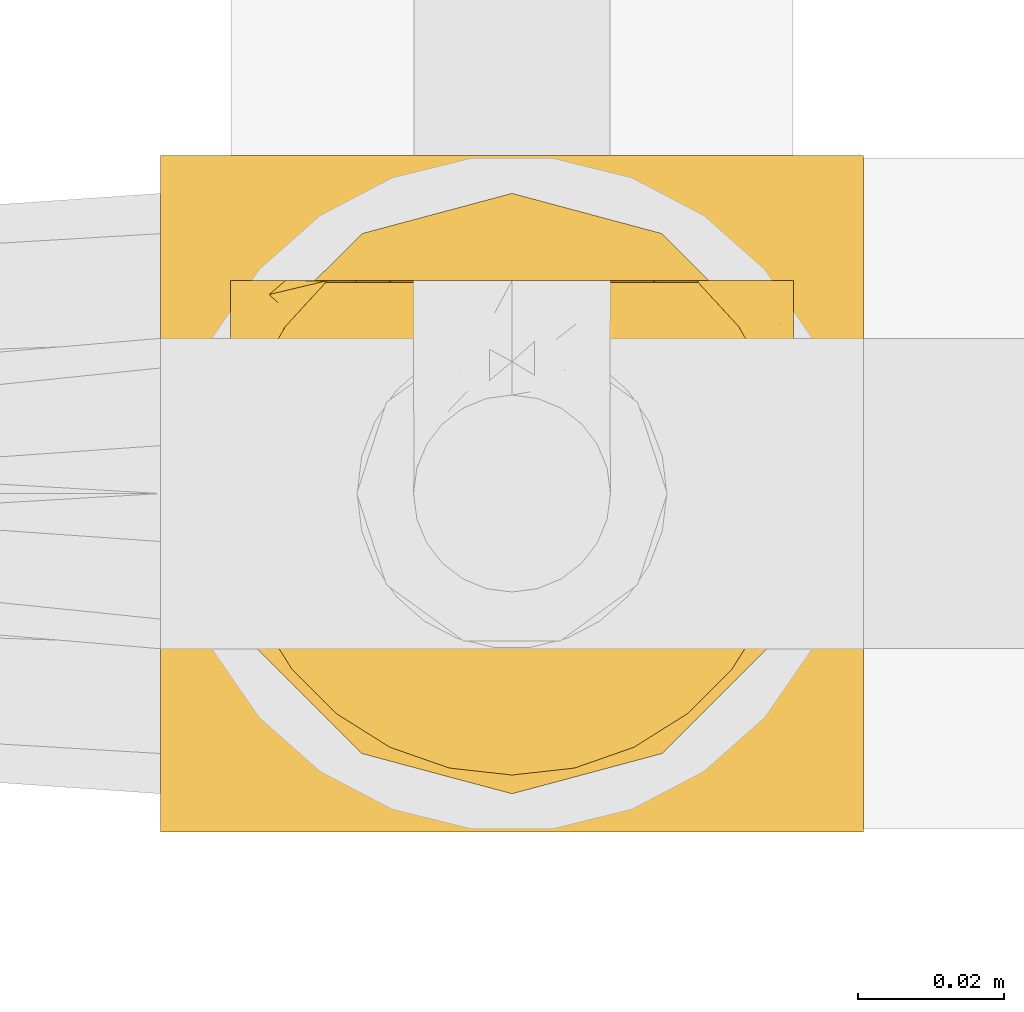
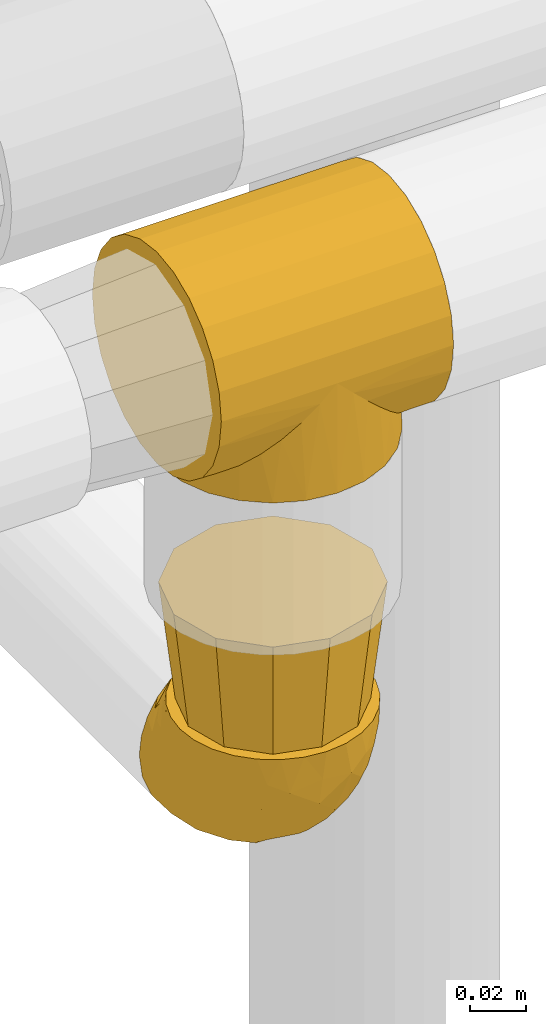
# One storey, part 99 of 827: 3 coverings.
"""IFC2X3 building model written with IfcOpenShell, lengths in millimetres."""

from ifc_helpers import new_model, entity, si_unit, converted_unit, derived_unit, direction, frame, origin, place, context, subcontext, project, spatial, faceted_brep, element, save


model = new_model("IFC2X3")

# Units and contexts
model_context = context("Model", 3, precision=0.01, world=origin(), true_north=direction((6.12303176911189e-17, 1.0)))
body_context = subcontext(model_context, "Body", "Model", "MODEL_VIEW")
ifc_project = project(units=[si_unit("LENGTHUNIT", "METRE", prefix="MILLI"), si_unit("AREAUNIT", "SQUARE_METRE"), si_unit("VOLUMEUNIT", "CUBIC_METRE"), converted_unit("PLANEANGLEUNIT", "DEGREE", entity("IfcRatioMeasure", 0.0174532925199433), si_unit("PLANEANGLEUNIT", "RADIAN"), dimensions=[0, 0, 0, 0, 0, 0, 0]), si_unit("MASSUNIT", "GRAM", prefix="KILO"), derived_unit("MASSDENSITYUNIT", [(si_unit("MASSUNIT", "GRAM", prefix="KILO"), 1), (si_unit("LENGTHUNIT", "METRE"), -3)]), derived_unit("MOMENTOFINERTIAUNIT", [(si_unit("LENGTHUNIT", "METRE"), 4)]), si_unit("TIMEUNIT", "SECOND"), si_unit("FREQUENCYUNIT", "HERTZ"), si_unit("THERMODYNAMICTEMPERATUREUNIT", "DEGREE_CELSIUS"), derived_unit("THERMALTRANSMITTANCEUNIT", [(si_unit("MASSUNIT", "GRAM", prefix="KILO"), 1), (si_unit("THERMODYNAMICTEMPERATUREUNIT", "KELVIN"), -1), (si_unit("TIMEUNIT", "SECOND"), -3)]), derived_unit("VOLUMETRICFLOWRATEUNIT", [(si_unit("LENGTHUNIT", "METRE"), 3), (si_unit("TIMEUNIT", "SECOND"), -1)]), derived_unit("MASSFLOWRATEUNIT", [(si_unit("MASSUNIT", "GRAM", prefix="KILO"), 1), (si_unit("TIMEUNIT", "SECOND"), -1)]), derived_unit("ROTATIONALFREQUENCYUNIT", [(si_unit("TIMEUNIT", "SECOND"), -1)]), si_unit("ELECTRICCURRENTUNIT", "AMPERE"), si_unit("ELECTRICVOLTAGEUNIT", "VOLT"), si_unit("POWERUNIT", "WATT"), si_unit("FORCEUNIT", "NEWTON", prefix="KILO"), si_unit("ILLUMINANCEUNIT", "LUX"), si_unit("LUMINOUSFLUXUNIT", "LUMEN"), si_unit("LUMINOUSINTENSITYUNIT", "CANDELA"), derived_unit("USERDEFINED", [(si_unit("MASSUNIT", "GRAM", prefix="KILO"), -1), (si_unit("LENGTHUNIT", "METRE"), -2), (si_unit("TIMEUNIT", "SECOND"), 3), (si_unit("LUMINOUSFLUXUNIT", "LUMEN"), 1)]), derived_unit("LINEARVELOCITYUNIT", [(si_unit("LENGTHUNIT", "METRE"), 1), (si_unit("TIMEUNIT", "SECOND"), -1)]), si_unit("PRESSUREUNIT", "PASCAL"), derived_unit("USERDEFINED", [(si_unit("LENGTHUNIT", "METRE"), -2), (si_unit("MASSUNIT", "GRAM", prefix="KILO"), 1), (si_unit("TIMEUNIT", "SECOND"), -2)]), derived_unit("LINEARFORCEUNIT", [(si_unit("MASSUNIT", "GRAM", prefix="KILO"), 1), (si_unit("LENGTHUNIT", "METRE"), 1), (si_unit("TIMEUNIT", "SECOND"), -2), (si_unit("LENGTHUNIT", "METRE"), -1)]), derived_unit("PLANARFORCEUNIT", [(si_unit("MASSUNIT", "GRAM", prefix="KILO"), 1), (si_unit("LENGTHUNIT", "METRE"), 1), (si_unit("TIMEUNIT", "SECOND"), -2), (si_unit("LENGTHUNIT", "METRE"), -2)])], contexts=[model_context])

# Site, building, storey
site_placement = place(None, origin())
site = spatial("IfcSite", under=ifc_project, at=site_placement, CompositionType="ELEMENT")
building_placement = place(site_placement, origin())
building = spatial("IfcBuilding", under=site, at=building_placement, CompositionType="ELEMENT")
storey_placement = place(building_placement, frame((0.0, 0.0, 28200.0)))
storey = spatial("IfcBuildingStorey", under=building, at=storey_placement, Name="08", CompositionType="ELEMENT", Elevation=28200.0)

# Coverings
covering_1_placement = place(storey_placement, frame((19728.27, 9295.0, 2948.46)))
element("IfcCovering", 1, at=covering_1_placement, inside=storey, Name=":ADSK_", ObjectType=":ADSK_", PredefinedType="INSULATION", context=body_context, shape_type="Brep", body=[
    faceted_brep([(54.91, 93.48, 41.09), (96.0, 94.0, 48.0), (96.0, 92.42, 36.04), (88.15, 70.23, 7.85), (96.0, 68.11, 6.84), (90.3, 66.38, 5.7), (96.0, 87.81, 24.9), (68.4, 89.25, 27.6), (74.78, 85.44, 21.22), (96.0, 80.46, 15.33), (96.0, 70.9, 7.99), (96.0, 59.75, 3.37), (92.82, 58.58, 3.18), (92.46, 59.69, 3.54), (91.74, 61.92, 4.26), (48.0, 94.0, 48.0), (41.09, 93.48, 41.09), (0.0, 94.0, 48.0), (93.18, 57.46, 2.82), (96.0, 58.26, 3.18), (96.0, 56.76, 2.98), (61.74, 91.91, 34.26), (96.0, 51.53, 2.29), (96.0, 50.78, 2.19), (93.82, 51.42, 2.18), (96.0, 52.28, 2.39), (86.0, 74.07, 10.0), (96.0, 75.68, 11.66), (96.0, 62.54, 4.53), (91.02, 64.15, 4.98), (96.0, 65.32, 5.68), (96.0, 49.29, 2.0), (94.07, 49.0, 1.93), (93.94, 50.21, 2.06), (93.69, 52.63, 2.31), (96.0, 55.27, 2.78), (96.0, 53.77, 2.59), (93.43, 55.05, 2.57), (80.72, 80.41, 15.28), (93.3, 56.26, 2.7), (93.56, 53.84, 2.44), (96.0, 47.8, 1.8), (94.2, 47.8, 1.8), (0.0, 47.8, 1.8), (1.93, 49.0, 1.93), (1.8, 47.8, 1.8), (96.0, 50.04, 2.1), (91.73, 33.66, 4.27), (96.0, 35.84, 3.37), (96.0, 33.05, 4.53), (96.0, 43.31, 2.39), (96.0, 41.82, 2.59), (93.69, 42.95, 2.31), (92.45, 35.89, 3.55), (92.81, 37.0, 3.19), (96.0, 30.27, 5.68), (90.3, 29.21, 5.7), (91.02, 31.43, 4.98), (93.17, 38.11, 2.83), (96.0, 38.83, 2.98), (96.0, 37.33, 3.18), (96.0, 27.48, 6.84), (96.0, 24.7, 7.99), (88.15, 25.37, 7.85), (86.0, 21.52, 10.0), (96.0, 19.91, 11.66), (80.73, 15.18, 15.27), (93.94, 45.37, 2.06), (96.0, 46.3, 2.0), (96.0, 45.55, 2.1), (96.0, 44.81, 2.19), (96.0, 15.13, 15.33), (74.79, 10.15, 21.21), (96.0, 7.78, 24.9), (93.43, 40.53, 2.57), (93.56, 41.74, 2.44), (68.4, 6.34, 27.6), (96.0, 3.17, 36.04), (93.3, 39.32, 2.7), (96.0, 40.32, 2.78), (54.91, 2.11, 41.09), (96.0, 1.6, 48.0), (61.74, 3.69, 34.26), (48.0, 1.6, 48.0), (41.09, 2.11, 41.09), (0.0, 1.6, 48.0), (94.07, 46.59, 1.93), (93.82, 44.16, 2.18), (96.0, 44.06, 2.29), (1.93, 46.59, 1.93), (0.0, 24.7, 88.01), (0.0, 35.84, 92.63), (0.0, 47.8, 94.2), (0.0, 59.75, 92.63), (0.0, 70.9, 88.01), (0.0, 80.46, 80.67), (0.0, 87.81, 71.1), (0.0, 92.42, 59.96), (0.0, 92.42, 36.04), (0.0, 87.81, 24.9), (0.0, 80.46, 15.33), (0.0, 75.68, 11.66), (0.0, 70.9, 7.99), (0.0, 68.11, 6.84), (0.0, 65.32, 5.68), (0.0, 62.54, 4.53), (0.0, 59.75, 3.37), (0.0, 58.26, 3.18), (0.0, 56.76, 2.98), (0.0, 55.27, 2.78), (0.0, 53.77, 2.59), (0.0, 52.28, 2.39), (0.0, 51.53, 2.29), (0.0, 50.78, 2.19), (0.0, 50.04, 2.1), (0.0, 49.29, 2.0), (0.0, 46.3, 2.0), (0.0, 45.55, 2.1), (0.0, 44.81, 2.19), (0.0, 44.06, 2.29), (0.0, 43.31, 2.39), (0.0, 41.82, 2.59), (0.0, 40.32, 2.78), (0.0, 38.83, 2.98), (0.0, 37.33, 3.18), (0.0, 35.84, 3.37), (0.0, 33.05, 4.53), (0.0, 30.27, 5.68), (0.0, 27.48, 6.84), (0.0, 24.7, 7.99), (0.0, 19.91, 11.66), (0.0, 15.13, 15.33), (0.0, 7.78, 24.9), (0.0, 3.17, 36.04), (0.0, 3.17, 59.96), (0.0, 7.78, 71.1), (0.0, 15.13, 80.67), (96.0, 92.42, 59.96), (96.0, 87.81, 71.1), (96.0, 80.46, 80.67), (96.0, 70.9, 88.01), (96.0, 59.75, 92.63), (96.0, 47.8, 94.2), (96.0, 35.84, 92.63), (96.0, 24.7, 88.01), (96.0, 15.13, 80.67), (96.0, 7.78, 71.1), (96.0, 3.17, 59.96), (4.26, 61.92, 4.26), (3.54, 59.69, 3.54), (3.18, 58.58, 3.18), (34.26, 91.91, 34.26), (27.6, 89.25, 27.6), (5.7, 66.38, 5.7), (2.7, 56.26, 2.7), (2.57, 55.05, 2.57), (21.22, 85.44, 21.22), (10.0, 74.07, 10.0), (7.85, 70.23, 7.85), (15.28, 80.41, 15.28), (4.98, 64.15, 4.98), (2.82, 57.46, 2.82), (2.06, 50.21, 2.06), (2.44, 53.84, 2.44), (2.31, 52.63, 2.31), (2.18, 51.42, 2.18), (5.7, 29.21, 5.7), (4.98, 31.43, 4.98), (10.0, 21.52, 10.0), (2.57, 40.53, 2.57), (15.27, 15.18, 15.27), (7.85, 25.37, 7.85), (2.7, 39.32, 2.7), (2.83, 38.11, 2.83), (2.18, 44.16, 2.18), (2.31, 42.95, 2.31), (4.27, 33.66, 4.27), (3.19, 37.0, 3.19), (3.55, 35.89, 3.55), (27.6, 6.34, 27.6), (34.26, 3.69, 34.26), (21.21, 10.15, 21.21), (2.44, 41.74, 2.44), (2.06, 45.37, 2.06), (48.0, 94.0, 0.0), (59.96, 92.42, 0.0), (71.1, 87.81, 0.0), (80.67, 80.46, 0.0), (84.34, 75.68, 0.0), (88.01, 70.9, 0.0), (89.16, 68.11, 0.0), (90.32, 65.32, 0.0), (91.47, 62.54, 0.0), (92.63, 59.75, 0.0), (92.82, 58.26, 0.0), (93.02, 56.76, 0.0), (93.22, 55.27, 0.0), (93.41, 53.77, 0.0), (93.61, 52.28, 0.0), (93.71, 51.53, 0.0), (93.81, 50.78, 0.0), (93.9, 50.04, 0.0), (94.0, 49.29, 0.0), (94.2, 47.8, 0.0), (94.0, 46.3, 0.0), (93.9, 45.55, 0.0), (93.81, 44.81, 0.0), (93.71, 44.06, 0.0), (93.61, 43.31, 0.0), (93.41, 41.82, 0.0), (93.22, 40.32, 0.0), (93.02, 38.83, 0.0), (92.82, 37.33, 0.0), (92.63, 35.84, 0.0), (91.47, 33.05, 0.0), (90.32, 30.27, 0.0), (89.16, 27.48, 0.0), (88.01, 24.7, 0.0), (84.34, 19.91, 0.0), (80.67, 15.13, 0.0), (71.1, 7.78, 0.0), (59.96, 3.17, 0.0), (48.0, 1.6, 0.0), (36.04, 3.17, 0.0), (24.9, 7.78, 0.0), (15.33, 15.13, 0.0), (11.66, 19.91, 0.0), (7.99, 24.7, 0.0), (6.84, 27.48, 0.0), (5.68, 30.27, 0.0), (4.53, 33.05, 0.0), (3.37, 35.84, 0.0), (3.18, 37.33, 0.0), (2.98, 38.83, 0.0), (2.78, 40.32, 0.0), (2.59, 41.82, 0.0), (2.39, 43.31, 0.0), (2.29, 44.06, 0.0), (2.19, 44.81, 0.0), (2.1, 45.55, 0.0), (2.0, 46.3, 0.0), (1.8, 47.8, 0.0), (2.0, 49.29, 0.0), (2.1, 50.04, 0.0), (2.19, 50.78, 0.0), (2.29, 51.53, 0.0), (2.39, 52.28, 0.0), (2.59, 53.77, 0.0), (2.78, 55.27, 0.0), (2.98, 56.76, 0.0), (3.18, 58.26, 0.0), (3.37, 59.75, 0.0), (4.53, 62.54, 0.0), (5.68, 65.32, 0.0), (6.84, 68.11, 0.0), (7.99, 70.9, 0.0), (11.66, 75.68, 0.0), (15.33, 80.46, 0.0), (24.9, 87.81, 0.0), (36.04, 92.42, 0.0)], [[[0, 1, 2]], [[3, 4, 5]], [[2, 6, 7]], [[8, 6, 9]], [[4, 3, 10]], [[8, 7, 6]], [[11, 12, 13, 14]], [[0, 15, 1]], [[15, 16, 17]], [[18, 19, 20]], [[7, 21, 2]], [[0, 2, 21]], [[19, 18, 12]], [[12, 11, 19]], [[22, 23, 24, 25]], [[26, 27, 10]], [[28, 29, 30]], [[28, 11, 14]], [[31, 32, 33]], [[29, 28, 14]], [[34, 25, 24]], [[35, 36, 37]], [[38, 9, 27]], [[38, 27, 26]], [[5, 30, 29]], [[20, 39, 18]], [[5, 4, 30]], [[26, 10, 3]], [[35, 39, 20]], [[9, 38, 8]], [[36, 34, 40, 37]], [[34, 36, 25]], [[39, 35, 37]], [[32, 41, 42]], [[43, 44, 45]], [[23, 33, 24]], [[33, 23, 46, 31]], [[41, 32, 31]], [[47, 48, 49]], [[50, 51, 52]], [[48, 47, 53, 54]], [[55, 56, 57]], [[58, 59, 60]], [[61, 62, 63]], [[49, 57, 47]], [[58, 60, 54]], [[64, 62, 65]], [[66, 64, 65]], [[61, 63, 56]], [[67, 68, 69, 70]], [[65, 71, 66]], [[62, 64, 63]], [[72, 71, 73]], [[51, 74, 75, 52]], [[76, 73, 77]], [[78, 79, 59]], [[59, 58, 78]], [[80, 77, 81]], [[79, 78, 74]], [[76, 72, 73]], [[80, 82, 77]], [[83, 80, 81]], [[84, 83, 85]], [[56, 55, 61]], [[76, 77, 82]], [[57, 49, 55]], [[48, 54, 60]], [[71, 72, 66]], [[74, 51, 79]], [[86, 41, 68]], [[87, 50, 52]], [[70, 87, 67]], [[50, 87, 70, 88]], [[41, 86, 42]], [[89, 43, 45]], [[68, 67, 86]], [[90, 91, 92, 93, 94, 95, 96, 97, 17, 98, 99, 100, 101, 102, 103, 104, 105, 106, 107, 108, 109, 110, 111, 112, 113, 114, 115, 43, 116, 117, 118, 119, 120, 121, 122, 123, 124, 125, 126, 127, 128, 129, 130, 131, 132, 133, 85, 134, 135, 136]], [[1, 137, 138, 139, 140, 141, 142, 143, 144, 145, 146, 147, 81, 77, 73, 71, 65, 62, 61, 55, 49, 48, 60, 59, 79, 51, 50, 88, 70, 69, 68, 41, 31, 46, 23, 22, 25, 36, 35, 20, 19, 11, 28, 30, 4, 10, 27, 9, 6, 2]], [[140, 139, 95, 94]], [[92, 142, 141, 93]], [[141, 140, 94, 93]], [[96, 138, 137, 97]], [[1, 15, 17, 97, 137]], [[95, 139, 138, 96]], [[106, 148, 149, 150]], [[151, 152, 98]], [[153, 104, 103]], [[148, 106, 105]], [[16, 151, 98]], [[109, 154, 155]], [[17, 16, 98]], [[99, 156, 100]], [[99, 98, 152]], [[156, 99, 152]], [[102, 157, 158]], [[106, 150, 107]], [[155, 110, 109]], [[157, 101, 159]], [[105, 160, 148]], [[161, 107, 150]], [[162, 115, 114, 113]], [[157, 102, 101]], [[153, 103, 158]], [[104, 153, 160]], [[159, 101, 100]], [[102, 158, 103]], [[108, 161, 154]], [[110, 155, 163, 164]], [[164, 111, 110]], [[161, 108, 107]], [[160, 105, 104]], [[159, 100, 156]], [[154, 109, 108]], [[44, 43, 115]], [[165, 111, 164]], [[113, 165, 162]], [[111, 165, 113, 112]], [[115, 162, 44]], [[166, 127, 167]], [[166, 128, 127]], [[129, 168, 130]], [[122, 121, 169]], [[170, 130, 168]], [[171, 168, 129]], [[123, 172, 173]], [[119, 118, 174, 120]], [[128, 171, 129]], [[174, 175, 120]], [[126, 125, 176]], [[171, 128, 166]], [[170, 131, 130]], [[125, 177, 178, 176]], [[179, 180, 133]], [[173, 124, 123]], [[177, 125, 124]], [[180, 84, 133]], [[131, 181, 132]], [[181, 131, 170]], [[179, 132, 181]], [[179, 133, 132]], [[121, 175, 182, 169]], [[167, 126, 176]], [[84, 85, 133]], [[126, 167, 127]], [[122, 172, 123]], [[124, 173, 177]], [[116, 89, 183]], [[175, 121, 120]], [[172, 122, 169]], [[118, 183, 174]], [[183, 118, 117, 116]], [[43, 89, 116]], [[83, 81, 147, 134, 85]], [[134, 147, 146, 135]], [[146, 145, 136, 135]], [[136, 145, 144, 90]], [[90, 144, 143, 91]], [[91, 143, 142, 92]], [[184, 185, 186, 187, 188, 189, 190, 191, 192, 193, 194, 195, 196, 197, 198, 199, 200, 201, 202, 203, 204, 205, 206, 207, 208, 209, 210, 211, 212, 213, 214, 215, 216, 217, 218, 219, 220, 221, 222, 223, 224, 225, 226, 227, 228, 229, 230, 231, 232, 233, 234, 235, 236, 237, 238, 239, 240, 241, 242, 243, 244, 245, 246, 247, 248, 249, 250, 251, 252, 253, 254, 255, 256, 257, 258, 259]], [[39, 196, 195]], [[198, 197, 34]], [[193, 14, 13, 12]], [[5, 191, 190]], [[14, 193, 192]], [[190, 189, 3]], [[192, 29, 14]], [[18, 194, 12]], [[26, 189, 188]], [[38, 26, 188]], [[190, 3, 5]], [[33, 202, 201, 200]], [[188, 187, 38]], [[189, 26, 3]], [[8, 187, 186]], [[29, 192, 191]], [[7, 186, 185]], [[193, 12, 194]], [[0, 185, 184]], [[191, 5, 29]], [[7, 8, 186]], [[197, 37, 40, 34]], [[0, 21, 185]], [[15, 0, 184]], [[18, 195, 194]], [[7, 185, 21]], [[196, 39, 37]], [[187, 8, 38]], [[37, 197, 196]], [[195, 18, 39]], [[32, 203, 202]], [[24, 198, 34]], [[200, 24, 33]], [[198, 24, 200, 199]], [[203, 32, 42]], [[202, 33, 32]], [[16, 184, 259]], [[158, 254, 153]], [[259, 258, 152]], [[156, 258, 257]], [[254, 158, 255]], [[156, 152, 258]], [[251, 150, 149, 148]], [[16, 15, 184]], [[161, 250, 249]], [[152, 151, 259]], [[16, 259, 151]], [[250, 161, 150]], [[150, 251, 250]], [[245, 244, 165, 246]], [[157, 256, 255]], [[252, 160, 253]], [[252, 251, 148]], [[242, 44, 162]], [[160, 252, 148]], [[164, 246, 165]], [[248, 247, 155]], [[159, 257, 256]], [[159, 256, 157]], [[153, 253, 160]], [[249, 154, 161]], [[153, 254, 253]], [[157, 255, 158]], [[248, 154, 249]], [[257, 159, 156]], [[247, 164, 163, 155]], [[164, 247, 246]], [[154, 248, 155]], [[44, 241, 45]], [[244, 162, 165]], [[162, 244, 243, 242]], [[241, 44, 242]], [[176, 231, 230]], [[236, 235, 175]], [[231, 176, 178, 177]], [[229, 166, 167]], [[173, 233, 232]], [[228, 227, 171]], [[230, 167, 176]], [[173, 232, 177]], [[168, 227, 226]], [[170, 168, 226]], [[228, 171, 166]], [[183, 240, 239, 238]], [[226, 225, 170]], [[227, 168, 171]], [[181, 225, 224]], [[235, 169, 182, 175]], [[179, 224, 223]], [[172, 234, 233]], [[233, 173, 172]], [[84, 223, 222]], [[234, 172, 169]], [[179, 181, 224]], [[84, 180, 223]], [[83, 84, 222]], [[166, 229, 228]], [[179, 223, 180]], [[167, 230, 229]], [[231, 177, 232]], [[225, 181, 170]], [[169, 235, 234]], [[89, 241, 240]], [[174, 236, 175]], [[238, 174, 183]], [[236, 174, 238, 237]], [[241, 89, 45]], [[240, 183, 89]], [[80, 222, 221]], [[209, 52, 75, 74]], [[221, 220, 76]], [[72, 220, 219]], [[210, 78, 211]], [[72, 76, 220]], [[63, 216, 56]], [[80, 83, 222]], [[54, 213, 212]], [[76, 82, 221]], [[80, 221, 82]], [[58, 212, 211]], [[216, 63, 217]], [[207, 206, 87, 208]], [[64, 218, 217]], [[204, 86, 67]], [[214, 213, 47]], [[57, 214, 47]], [[212, 58, 54]], [[52, 208, 87]], [[210, 209, 74]], [[66, 219, 218]], [[66, 218, 64]], [[56, 215, 57]], [[211, 78, 58]], [[56, 216, 215]], [[64, 217, 63]], [[213, 54, 53, 47]], [[219, 66, 72]], [[214, 57, 215]], [[52, 209, 208]], [[78, 210, 74]], [[86, 203, 42]], [[206, 67, 87]], [[67, 206, 205, 204]], [[203, 86, 204]]]),
])
covering_2_placement = place(storey_placement, frame((19736.22, 9302.75, 2761.68)))
element("IfcCovering", 2, at=covering_2_placement, inside=storey, Name=":ADSK_", ObjectType=":ADSK_", PredefinedType="INSULATION", context=body_context, shape_type="Brep", body=[
    faceted_brep([(5.41, 23.36, 69.15), (9.99, 16.07, 69.15), (16.08, 9.98, 69.15), (23.37, 5.4, 69.15), (31.49, 2.56, 69.15), (40.05, 1.6, 69.15), (48.61, 2.56, 69.15), (56.73, 5.41, 69.15), (64.02, 9.99, 69.15), (70.11, 16.08, 69.15), (74.69, 23.37, 69.15), (77.53, 31.49, 69.15), (78.5, 40.05, 69.15), (77.63, 48.15, 69.15), (75.08, 55.88, 69.15), (70.97, 62.9, 69.15), (65.47, 68.89, 69.15), (63.27, 68.89, 69.15), (61.53, 68.89, 69.15), (59.57, 68.89, 69.15), (57.6, 68.89, 69.15), (55.63, 68.89, 69.15), (53.67, 68.89, 69.15), (51.7, 68.89, 69.15), (49.73, 68.89, 69.15), (47.54, 68.89, 69.15), (45.34, 68.89, 69.15), (43.15, 68.89, 69.15), (40.96, 68.89, 69.15), (38.76, 68.89, 69.15), (36.57, 68.89, 69.15), (34.37, 68.89, 69.15), (32.18, 68.89, 69.15), (29.98, 68.89, 69.15), (27.79, 68.89, 69.15), (25.6, 68.89, 69.15), (23.4, 68.89, 69.15), (21.21, 68.89, 69.15), (19.01, 68.89, 69.15), (16.82, 68.89, 69.15), (14.62, 68.89, 69.15), (9.12, 62.89, 69.15), (5.0, 55.86, 69.15), (2.46, 48.13, 69.15), (1.6, 40.05, 69.15), (2.56, 31.49, 69.15), (65.47, 69.15, 68.89), (70.97, 69.15, 62.89), (75.09, 69.15, 55.87), (77.63, 69.15, 48.14), (78.5, 69.15, 40.05), (77.19, 69.15, 30.09), (73.34, 69.15, 20.82), (67.23, 69.15, 12.86), (59.27, 69.15, 6.75), (50.0, 69.15, 2.91), (40.05, 69.15, 1.6), (30.09, 69.15, 2.91), (20.82, 69.15, 6.75), (12.86, 69.15, 12.86), (6.75, 69.15, 20.82), (2.91, 69.15, 30.09), (1.6, 69.15, 40.05), (2.46, 69.15, 48.14), (5.0, 69.15, 55.87), (9.12, 69.15, 62.89), (14.62, 69.15, 68.89), (16.82, 69.15, 68.89), (17.8, 69.15, 68.89), (19.39, 69.15, 68.89), (20.98, 69.15, 68.89), (22.57, 69.15, 68.89), (24.16, 69.15, 68.89), (25.75, 69.15, 68.89), (27.33, 69.15, 68.89), (28.92, 69.15, 68.89), (30.51, 69.15, 68.89), (32.1, 69.15, 68.89), (33.69, 69.15, 68.89), (35.28, 69.15, 68.89), (36.87, 69.15, 68.89), (38.46, 69.15, 68.89), (40.05, 69.15, 68.89), (41.63, 69.15, 68.89), (43.22, 69.15, 68.89), (44.81, 69.15, 68.89), (46.4, 69.15, 68.89), (47.99, 69.15, 68.89), (49.58, 69.15, 68.89), (51.17, 69.15, 68.89), (52.76, 69.15, 68.89), (54.72, 69.15, 68.89), (56.69, 69.15, 68.89), (58.88, 69.15, 68.89), (61.08, 69.15, 68.89), (63.27, 69.15, 68.89), (37.77, 68.96, 68.97), (36.07, 68.97, 68.96), (32.96, 68.97, 68.97), (31.36, 68.97, 68.97), (56.52, 68.95, 68.98), (54.96, 68.96, 68.97), (18.75, 68.98, 68.96), (58.07, 68.97, 68.96), (50.37, 68.97, 68.96), (23.36, 68.98, 68.96), (24.95, 68.97, 68.96), (42.43, 68.97, 68.96), (15.97, 68.94, 69.0), (51.96, 68.98, 68.96), (53.47, 68.98, 68.96), (48.63, 68.96, 68.97), (63.93, 68.97, 68.96), (40.93, 68.98, 68.96), (29.72, 68.98, 68.96), (62.4, 68.97, 68.97), (60.92, 68.96, 68.97), (17.31, 68.97, 68.97), (21.74, 68.97, 68.96), (34.56, 68.98, 68.96), (20.18, 68.96, 68.97), (14.62, 68.97, 68.97), (14.62, 68.94, 69.02), (14.62, 68.92, 69.08), (65.47, 68.97, 68.97), (65.47, 69.02, 68.94), (65.47, 69.08, 68.92), (59.5, 68.98, 68.96), (47.1, 68.97, 68.96), (45.61, 68.98, 68.95), (28.18, 68.97, 68.96), (14.62, 69.08, 68.92), (14.62, 69.02, 68.94), (26.61, 68.96, 68.98), (65.47, 68.92, 69.08), (65.47, 68.94, 69.02), (39.32, 68.97, 68.96), (44.12, 68.96, 68.97), (72.26, 67.02, 61.33), (76.57, 63.33, 53.1), (71.77, 64.61, 63.33), (78.5, 49.27, 49.27), (77.9, 51.4, 55.53), (78.5, 43.94, 54.6), (78.5, 61.87, 41.99), (75.52, 61.54, 57.07), (76.13, 57.95, 57.95), (77.81, 56.12, 51.56), (78.5, 63.4, 41.58), (72.4, 65.41, 61.7), (76.56, 53.1, 63.33), (71.77, 63.04, 65.0), (72.25, 61.33, 67.02), (78.5, 41.99, 61.87), (78.5, 54.6, 43.94), (75.75, 56.6, 61.21), (78.5, 41.58, 63.4), (50.46, 13.72, 33.11), (52.75, 5.82, 52.82), (40.05, 6.74, 43.3), (77.7, 58.82, 33.73), (77.66, 51.58, 36.52), (71.02, 42.09, 24.87), (63.45, 46.12, 14.17), (70.55, 55.56, 18.43), (75.57, 52.38, 28.67), (75.57, 61.54, 26.0), (72.61, 23.76, 49.25), (72.61, 20.5, 59.72), (67.24, 14.64, 55.1), (77.74, 41.77, 44.72), (57.43, 16.28, 34.15), (47.19, 49.4, 5.25), (54.76, 52.34, 6.75), (40.05, 4.3, 55.54), (63.45, 58.67, 10.47), (60.1, 25.26, 25.49), (63.72, 20.17, 35.53), (76.83, 34.7, 48.22), (76.34, 28.67, 58.71), (60.51, 8.62, 57.42), (72.59, 33.37, 34.84), (76.05, 41.35, 36.87), (66.15, 17.15, 45.01), (60.51, 12.68, 44.4), (51.88, 21.47, 23.96), (55.34, 41.11, 11.2), (48.67, 37.53, 10.56), (53.89, 30.64, 16.81), (46.73, 26.66, 17.38), (40.05, 21.38, 21.38), (40.05, 14.06, 32.34), (40.05, 55.54, 4.3), (63.95, 35.17, 20.65), (67.24, 29.04, 29.66), (69.62, 24.34, 39.6), (73.6, 29.33, 42.55), (40.05, 43.3, 6.74), (40.05, 32.34, 14.06), (4.52, 57.75, 26.84), (32.72, 49.41, 5.28), (27.18, 27.85, 18.52), (29.63, 13.7, 33.13), (12.86, 14.63, 55.1), (19.59, 8.61, 57.43), (9.54, 48.85, 20.72), (16.64, 54.13, 11.46), (17.48, 37.84, 17.69), (7.49, 23.75, 49.26), (7.49, 20.49, 59.73), (3.75, 28.66, 58.71), (20.75, 20.83, 29.72), (2.33, 55.15, 35.35), (1.6, 54.6, 43.94), (1.6, 61.87, 41.99), (1.6, 41.58, 63.4), (26.94, 57.58, 4.93), (9.54, 59.91, 17.46), (31.21, 36.94, 10.94), (25.33, 45.72, 8.92), (27.35, 5.82, 52.83), (8.17, 37.91, 29.34), (4.3, 50.18, 30.26), (19.59, 12.67, 44.4), (2.23, 49.29, 39.06), (2.45, 42.64, 43.06), (1.6, 43.94, 54.6), (1.6, 49.27, 49.27), (12.86, 19.45, 42.69), (3.27, 34.7, 48.2), (1.6, 41.99, 61.87), (2.29, 62.29, 33.44), (12.86, 29.01, 29.67), (6.89, 31.47, 38.5), (12.43, 37.18, 23.35), (4.1, 43.45, 34.97), (3.53, 63.33, 53.1), (6.88, 67.23, 59.68), (8.16, 66.07, 62.19), (9.02, 65.22, 64.11), (5.0, 61.99, 57.97), (3.96, 57.95, 57.95), (3.52, 53.09, 63.33), (2.4, 56.84, 51.77), (7.83, 61.33, 67.02), (8.32, 63.06, 64.98), (2.19, 51.41, 55.53), (4.34, 56.61, 61.22)], [[[0, 1, 2, 3, 4, 5, 6, 7, 8, 9, 10, 11, 12, 13, 14, 15, 16, 17, 18, 19, 20, 21, 22, 23, 24, 25, 26, 27, 28, 29, 30, 31, 32, 33, 34, 35, 36, 37, 38, 39, 40, 41, 42, 43, 44, 45]], [[46, 47, 48, 49, 50, 51, 52, 53, 54, 55, 56, 57, 58, 59, 60, 61, 62, 63, 64, 65, 66, 67, 68, 69, 70, 71, 72, 73, 74, 75, 76, 77, 78, 79, 80, 81, 82, 83, 84, 85, 86, 87, 88, 89, 90, 91, 92, 93, 94, 95]], [[96, 97, 30]], [[98, 77, 99]], [[100, 101, 21]], [[69, 68, 102]], [[20, 19, 103]], [[24, 23, 104]], [[20, 103, 100]], [[72, 105, 106]], [[84, 83, 107]], [[89, 88, 104]], [[108, 67, 66]], [[109, 110, 90]], [[111, 25, 24]], [[112, 17, 16]], [[82, 113, 83]], [[109, 23, 22]], [[114, 76, 75]], [[105, 36, 106]], [[104, 111, 24]], [[18, 115, 116]], [[97, 96, 80]], [[67, 108, 117]], [[105, 71, 118]], [[31, 97, 119]], [[102, 120, 69]], [[108, 121, 122, 123, 40]], [[112, 95, 115]], [[17, 115, 18]], [[94, 116, 115]], [[117, 68, 67]], [[38, 117, 39]], [[112, 124, 125, 126, 46]], [[17, 112, 115]], [[70, 120, 118]], [[39, 117, 108]], [[120, 38, 37]], [[120, 37, 118]], [[120, 70, 69]], [[116, 94, 127]], [[128, 86, 129]], [[117, 38, 102]], [[74, 130, 75]], [[99, 33, 32]], [[115, 95, 94]], [[39, 108, 40]], [[108, 66, 131, 132, 121]], [[105, 72, 71]], [[118, 37, 36]], [[71, 70, 118]], [[35, 106, 36]], [[36, 105, 118]], [[35, 133, 106]], [[74, 73, 133]], [[106, 133, 73]], [[99, 114, 33]], [[133, 35, 34]], [[73, 72, 106]], [[95, 112, 46]], [[112, 16, 134, 135, 124]], [[130, 114, 75]], [[99, 76, 114]], [[114, 130, 33]], [[34, 33, 130]], [[78, 77, 98]], [[98, 119, 78]], [[130, 133, 34]], [[133, 130, 74]], [[79, 97, 80]], [[98, 99, 32]], [[98, 32, 31]], [[77, 76, 99]], [[97, 79, 119]], [[136, 96, 29]], [[30, 97, 31]], [[136, 29, 28]], [[81, 80, 96]], [[29, 96, 30]], [[31, 119, 98]], [[119, 79, 78]], [[96, 136, 81]], [[82, 81, 136]], [[113, 107, 83]], [[84, 107, 137]], [[107, 27, 137]], [[113, 28, 107]], [[27, 107, 28]], [[85, 84, 137]], [[137, 27, 26]], [[113, 136, 28]], [[136, 113, 82]], [[109, 89, 104]], [[86, 85, 129]], [[89, 109, 90]], [[111, 87, 128]], [[26, 129, 137]], [[88, 111, 104]], [[25, 111, 128]], [[22, 110, 109]], [[23, 109, 104]], [[110, 91, 90]], [[100, 92, 101]], [[110, 22, 101]], [[91, 110, 101]], [[116, 19, 18]], [[111, 88, 87]], [[127, 103, 19]], [[25, 128, 26]], [[86, 128, 87]], [[128, 129, 26]], [[137, 129, 85]], [[120, 102, 38]], [[117, 102, 68]], [[91, 101, 92]], [[21, 101, 22]], [[93, 92, 103]], [[100, 21, 20]], [[100, 103, 92]], [[127, 93, 103]], [[93, 127, 94]], [[116, 127, 19]], [[126, 138, 47]], [[48, 138, 139]], [[140, 125, 124]], [[141, 142, 143]], [[144, 49, 139]], [[145, 140, 146]], [[48, 139, 49]], [[139, 145, 147]], [[49, 144, 148, 50]], [[126, 125, 149]], [[14, 13, 150]], [[151, 146, 140]], [[149, 140, 145]], [[152, 151, 135]], [[152, 14, 150]], [[16, 15, 134]], [[13, 153, 150]], [[124, 151, 140]], [[141, 147, 142]], [[14, 152, 15]], [[15, 152, 134]], [[47, 46, 126]], [[139, 154, 144]], [[138, 48, 47]], [[125, 140, 149]], [[135, 134, 152]], [[146, 155, 142]], [[145, 146, 147]], [[149, 139, 138]], [[147, 141, 154]], [[147, 146, 142]], [[139, 147, 154]], [[139, 149, 145]], [[149, 138, 126]], [[155, 146, 151]], [[150, 143, 142]], [[152, 155, 151]], [[150, 142, 155]], [[13, 12, 156, 153]], [[153, 143, 150]], [[152, 150, 155]], [[151, 124, 135]], [[157, 158, 159]], [[160, 154, 161]], [[162, 163, 164]], [[165, 166, 160]], [[167, 168, 169]], [[141, 170, 161]], [[156, 12, 11]], [[158, 157, 171]], [[172, 55, 173]], [[158, 6, 174]], [[175, 54, 53]], [[52, 166, 164]], [[52, 164, 53]], [[54, 175, 173]], [[166, 52, 51]], [[176, 177, 171]], [[178, 143, 179]], [[156, 11, 179]], [[8, 7, 180]], [[169, 9, 8]], [[179, 143, 153, 156]], [[179, 11, 10]], [[168, 179, 10]], [[181, 162, 182]], [[179, 167, 178]], [[183, 184, 177]], [[183, 169, 184]], [[176, 171, 185]], [[172, 186, 187]], [[158, 7, 6]], [[159, 158, 174]], [[184, 180, 158]], [[54, 173, 55]], [[180, 169, 8]], [[188, 189, 187]], [[9, 168, 10]], [[186, 188, 187]], [[190, 157, 159, 191]], [[55, 172, 192]], [[176, 193, 194]], [[161, 170, 182]], [[162, 164, 165]], [[175, 164, 163]], [[51, 50, 148]], [[167, 195, 196]], [[178, 182, 170]], [[6, 5, 174]], [[158, 180, 7]], [[169, 180, 184]], [[169, 168, 9]], [[179, 168, 167]], [[182, 162, 165]], [[162, 194, 193]], [[161, 165, 160]], [[195, 181, 196]], [[192, 172, 197]], [[192, 56, 55]], [[189, 190, 198]], [[198, 197, 187]], [[172, 187, 197]], [[185, 189, 188]], [[198, 187, 189]], [[186, 172, 173]], [[173, 163, 186]], [[193, 186, 163]], [[176, 185, 188]], [[185, 157, 190]], [[188, 186, 193]], [[177, 176, 194]], [[188, 193, 176]], [[162, 193, 163]], [[195, 177, 194]], [[171, 177, 184]], [[181, 195, 194]], [[183, 167, 169]], [[162, 181, 194]], [[196, 182, 178]], [[158, 171, 184]], [[171, 157, 185]], [[177, 195, 183]], [[167, 183, 195]], [[182, 196, 181]], [[178, 170, 143]], [[178, 167, 196]], [[164, 175, 53]], [[173, 175, 163]], [[160, 51, 148]], [[164, 166, 165]], [[51, 160, 166]], [[160, 148, 144, 154]], [[141, 161, 154]], [[182, 165, 161]], [[190, 189, 185]], [[143, 170, 141]], [[60, 199, 61]], [[197, 200, 192]], [[201, 190, 202]], [[200, 57, 192]], [[203, 204, 2]], [[205, 206, 207]], [[208, 209, 210]], [[211, 207, 201]], [[212, 213, 214]], [[45, 215, 210]], [[216, 206, 58]], [[45, 44, 215]], [[59, 217, 60]], [[60, 217, 199]], [[0, 45, 210]], [[218, 201, 219]], [[202, 159, 220]], [[205, 221, 222]], [[223, 204, 203]], [[1, 203, 2]], [[57, 200, 216]], [[220, 3, 204]], [[220, 174, 4]], [[1, 0, 209]], [[212, 224, 213]], [[225, 226, 227]], [[228, 223, 203]], [[208, 210, 229]], [[210, 226, 229]], [[3, 220, 4]], [[58, 206, 59]], [[209, 203, 1]], [[202, 220, 223]], [[228, 203, 208]], [[202, 211, 201]], [[3, 2, 204]], [[202, 190, 191, 159]], [[210, 215, 230, 226]], [[199, 212, 231]], [[232, 233, 221]], [[233, 208, 229]], [[207, 206, 219]], [[217, 206, 205]], [[227, 224, 225]], [[233, 232, 228]], [[201, 207, 219]], [[234, 232, 221]], [[218, 219, 200]], [[202, 223, 211]], [[174, 220, 159]], [[174, 5, 4]], [[61, 231, 62]], [[220, 204, 223]], [[210, 209, 0]], [[203, 209, 208]], [[225, 233, 229]], [[224, 227, 213]], [[221, 233, 235]], [[57, 56, 192]], [[198, 218, 197]], [[200, 219, 216]], [[201, 198, 190]], [[197, 218, 200]], [[198, 201, 218]], [[206, 216, 219]], [[58, 57, 216]], [[231, 212, 214]], [[222, 212, 199]], [[228, 211, 223]], [[207, 211, 232]], [[62, 231, 214]], [[199, 231, 61]], [[233, 228, 208]], [[211, 228, 232]], [[222, 221, 235]], [[234, 205, 207]], [[206, 217, 59]], [[199, 217, 205]], [[205, 222, 199]], [[224, 222, 235]], [[222, 224, 212]], [[224, 235, 225]], [[233, 225, 235]], [[226, 225, 229]], [[205, 234, 221]], [[207, 232, 234]], [[63, 214, 236]], [[214, 213, 236]], [[214, 63, 62]], [[237, 236, 238]], [[238, 132, 131]], [[236, 237, 64]], [[239, 240, 241]], [[63, 236, 64]], [[131, 66, 65]], [[237, 131, 65]], [[242, 230, 43]], [[237, 65, 64]], [[239, 121, 132]], [[42, 242, 43]], [[241, 240, 243]], [[41, 123, 244]], [[43, 230, 215, 44]], [[244, 122, 245]], [[227, 246, 243]], [[241, 247, 245]], [[121, 239, 245]], [[41, 40, 123]], [[132, 238, 239]], [[244, 42, 41]], [[131, 237, 238]], [[240, 239, 238]], [[245, 239, 241]], [[247, 241, 246]], [[247, 244, 245]], [[238, 236, 240]], [[243, 236, 213]], [[236, 243, 240]], [[227, 226, 246]], [[243, 213, 227]], [[242, 246, 226]], [[243, 246, 241]], [[246, 242, 247]], [[244, 247, 242]], [[242, 226, 230]], [[42, 244, 242]], [[122, 244, 123]], [[122, 121, 245]]]),
])
covering_3_placement = place(storey_placement, frame((19733.67, 9300.2, 2830.83)))
element("IfcCovering", 3, at=covering_3_placement, inside=storey, Name=":ADSK_", ObjectType=":ADSK_", PredefinedType="INSULATION", context=body_context, shape_type="Brep", body=[
    faceted_brep([(14.59, 70.6, 51.0), (7.09, 63.1, 51.0), (5.43, 56.92, 51.0), (3.51, 49.76, 51.0), (1.6, 42.6, 51.0), (3.51, 35.43, 51.0), (5.43, 28.27, 51.0), (7.09, 22.1, 51.0), (14.59, 14.59, 51.0), (22.1, 7.09, 51.0), (28.27, 5.43, 51.0), (35.43, 3.51, 51.0), (42.6, 1.6, 51.0), (49.76, 3.51, 51.0), (56.92, 5.43, 51.0), (63.1, 7.09, 51.0), (70.6, 14.59, 51.0), (78.1, 22.1, 51.0), (79.76, 28.27, 51.0), (81.68, 35.43, 51.0), (83.6, 42.6, 51.0), (81.68, 49.76, 51.0), (79.76, 56.92, 51.0), (78.1, 63.1, 51.0), (70.6, 70.6, 51.0), (63.1, 78.1, 51.0), (56.92, 79.76, 51.0), (49.76, 81.68, 51.0), (42.6, 83.6, 51.0), (35.43, 81.68, 51.0), (28.27, 79.76, 51.0), (22.1, 78.1, 51.0), (66.5, 66.5, 0.0), (72.91, 60.1, 0.0), (75.25, 51.35, 0.0), (77.6, 42.6, 0.0), (75.25, 33.85, 0.0), (72.91, 25.1, 0.0), (66.5, 18.69, 0.0), (60.1, 12.28, 0.0), (51.35, 9.94, 0.0), (42.6, 7.6, 0.0), (33.85, 9.94, 0.0), (25.1, 12.28, 0.0), (18.69, 18.69, 0.0), (12.28, 25.1, 0.0), (9.94, 33.85, 0.0), (7.6, 42.6, 0.0), (9.94, 51.35, 0.0), (12.28, 60.1, 0.0), (18.69, 66.5, 0.0), (25.1, 72.91, 0.0), (33.85, 75.25, 0.0), (42.6, 77.6, 0.0), (51.35, 75.25, 0.0), (60.1, 72.91, 0.0)], [[[0, 1, 2, 3, 4, 5, 6, 7, 8, 9, 10, 11, 12, 13, 14, 15, 16, 17, 18, 19, 20, 21, 22, 23, 24, 25, 26, 27, 28, 29, 30, 31]], [[32, 33, 34, 35, 36, 37, 38, 39, 40, 41, 42, 43, 44, 45, 46, 47, 48, 49, 50, 51, 52, 53, 54, 55]], [[33, 23, 22, 21, 20, 35, 34]], [[24, 23, 33, 32, 55, 25]], [[27, 26, 25, 55, 54, 53, 28]], [[51, 31, 30, 29, 28, 53, 52]], [[0, 31, 51, 50, 49, 1]], [[3, 2, 1, 49, 48, 47, 4]], [[45, 7, 6, 5, 4, 47, 46]], [[8, 7, 45, 44, 43, 9]], [[11, 10, 9, 43, 42, 41, 12]], [[39, 15, 14, 13, 12, 41, 40]], [[16, 15, 39, 38, 37, 17]], [[19, 18, 17, 37, 36, 35, 20]]]),
])

save(model, "model.ifc")
